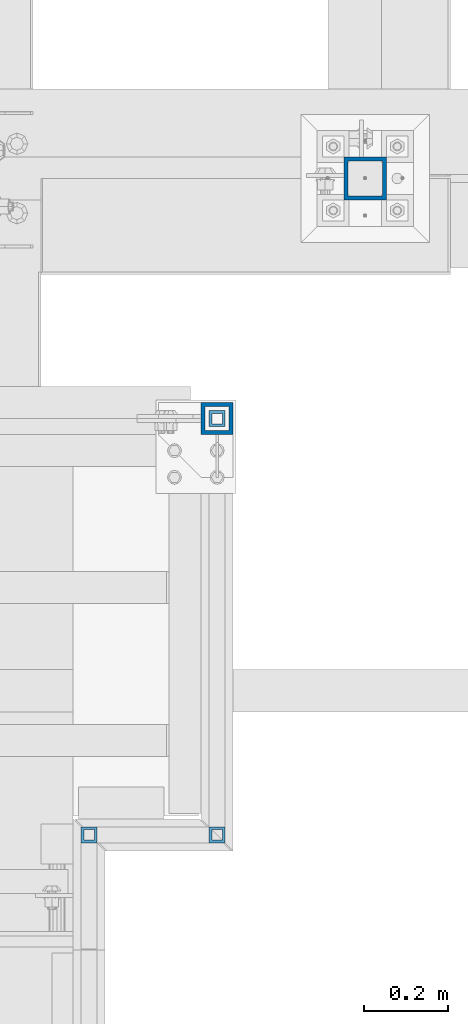
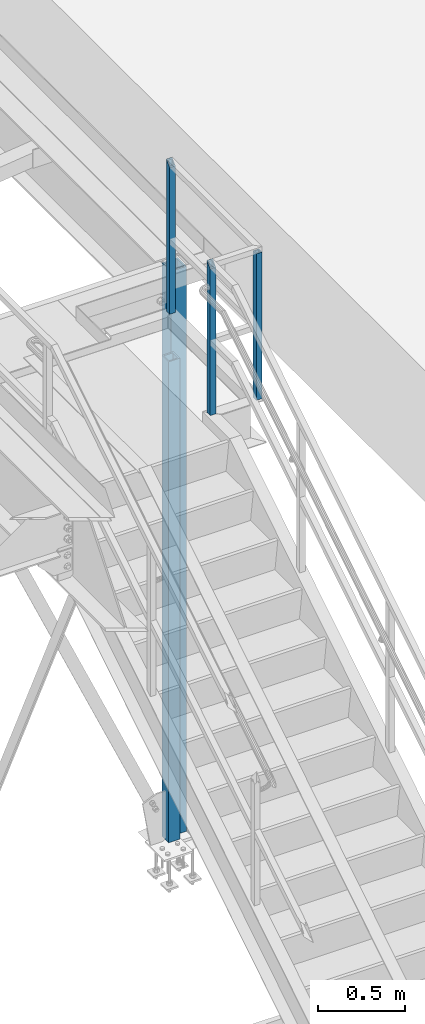
# One storey, part 1323 of 3843: 5 columns, 4 elements without a shape of their own.
"""IFC2X3 building model written with IfcOpenShell, lengths in millimetres."""

from ifc_helpers import new_model, si_unit, frame, origin_with_axes, place, context, subcontext, project, spatial, faceted_brep, material, type_object, element, aggregate, save


model = new_model("IFC2X3")

# Units and contexts
model_context = context("Model", 3, precision=1e-05, world=origin_with_axes())
body_context = subcontext(model_context, "Body", "Model", "MODEL_VIEW")
ifc_project = project(units=[si_unit("LENGTHUNIT", "METRE", prefix="MILLI"), si_unit("AREAUNIT", "SQUARE_METRE"), si_unit("VOLUMEUNIT", "CUBIC_METRE"), si_unit("MASSUNIT", "GRAM", prefix="KILO"), si_unit("TIMEUNIT", "SECOND"), si_unit("PLANEANGLEUNIT", "RADIAN"), si_unit("SOLIDANGLEUNIT", "STERADIAN"), si_unit("THERMODYNAMICTEMPERATUREUNIT", "DEGREE_CELSIUS"), si_unit("LUMINOUSINTENSITYUNIT", "LUMEN")], contexts=[model_context])

# Site, building, storey
site_placement = place(None, origin_with_axes())
site = spatial("IfcSite", under=ifc_project, at=site_placement, CompositionType="ELEMENT")
building_placement = place(site_placement, origin_with_axes())
building = spatial("IfcBuilding", under=site, at=building_placement, Name="Undefined", CompositionType="ELEMENT")
storey_placement = place(building_placement, origin_with_axes())
storey = spatial("IfcBuildingStorey", under=building, at=storey_placement, Name="Undefined", CompositionType="ELEMENT", Elevation=0.0)

# Assembly, columns
assembly_1_placement = place(storey_placement, origin_with_axes())
assembly_1 = element("IfcElementAssembly", 1, at=assembly_1_placement, inside=storey, Name="RAIL", AssemblyPlace="NOTDEFINED", PredefinedType="RIGID_FRAME")
ifc_material_1 = material()
column_type_1 = type_object("IfcColumnType", Name="HSS1-1/2X1-1/2X1/4", PredefinedType="NOTDEFINED")
column_1_placement = place(assembly_1_placement, frame((38468.2999999524, 33274.0, 34163.0), z_axis=(0.0, -1.0, 0.0), x_axis=(0.0, 0.0, 1.0)))
column_1 = element("IfcColumn", 2, at=column_1_placement, type_object=column_type_1, material=ifc_material_1, Name="POST", ObjectType="HSS1-1/2X1-1/2X1/4", context=body_context, shape_type="Brep", body=[
    faceted_brep([(0.0, 12.6999993299978, -12.6999993300014), (0.0, -12.6999993299978, -12.6999993300014), (1054.10000067001, -12.6999993300014, -12.6999993299978), (1054.10000067001, 12.6999993300014, -12.6999993299978), (0.0, -12.6999993299978, 12.6999993300014), (1028.70000067002, -12.6999993299978, 12.6999993299978), (0.0, 12.6999993299978, 12.6999993300014), (1028.70000067002, 12.6999993299978, 12.6999993299978), (0.0, 19.0500000000029, -19.0499999999993), (0.0, 19.0499992350015, 19.0499992350015), (1022.35000076501, 19.0499992350015, 19.0499992350015), (1060.44999923502, 19.0499992350015, -19.0499992350015), (0.0, -19.0499992350015, 19.0499992350015), (1022.35000076501, -19.0499992350015, 19.0499992350015), (0.0, -19.0499992350015, -19.0499992350015), (1060.44999923502, -19.0499992350015, -19.0499992350015)], [[[0, 1, 2, 3]], [[1, 4, 5, 2]], [[4, 6, 7, 5]], [[6, 0, 3, 7]], [[8, 9, 10, 11]], [[9, 12, 13, 10]], [[12, 14, 15, 13]], [[14, 8, 11, 15]], [[13, 15, 11, 10], [5, 7, 3, 2]], [[14, 12, 9, 8], [6, 4, 1, 0]]]),
])
column_2_placement = place(assembly_1_placement, frame((38468.2999999524, 32283.4, 34163.0), z_axis=(0.0, -1.0, 0.0), x_axis=(0.0, 0.0, 1.0)))
column_2 = element("IfcColumn", 3, at=column_2_placement, type_object=column_type_1, material=ifc_material_1, Name="POST", ObjectType="HSS1-1/2X1-1/2X1/4", context=body_context, shape_type="Brep", body=[
    faceted_brep([(0.0, 12.6999993299978, -12.6999993300014), (0.0, -12.6999993299978, -12.6999993300014), (1022.35000076501, -12.6999993299978, -12.6999993300014), (1022.35000076501, 12.6999993299978, -12.6999993300014), (0.0, -12.6999993299978, 12.6999993300014), (1022.35000076501, -12.6999993299978, 12.6999993300014), (0.0, 12.6999993299978, 12.6999993300014), (1022.35000076501, 12.6999993299978, 12.6999993300014), (0.0, 19.0500000000029, -19.0499999999993), (0.0, 19.0499992350015, 19.0499992350015), (1022.35000076501, 19.0499992350015, 19.0499992350015), (1022.35000076501, 19.0499992350015, -19.0499992350015), (0.0, -19.0499992350015, 19.0499992350015), (1022.35000076501, -19.0499992350015, 19.0499992350015), (0.0, -19.0499992350015, -19.0499992350015), (1022.35000076501, -19.0499992350015, -19.0499992350015)], [[[0, 1, 2, 3]], [[1, 4, 5, 2]], [[4, 6, 7, 5]], [[6, 0, 3, 7]], [[8, 9, 10, 11]], [[9, 12, 13, 10]], [[12, 14, 15, 13]], [[14, 8, 11, 15]], [[13, 15, 11, 10], [5, 7, 3, 2]], [[14, 12, 9, 8], [6, 4, 1, 0]]]),
])
aggregate(assembly_1, [column_1, column_2])

# Assembly, column
assembly_2_placement = place(storey_placement, origin_with_axes())
assembly_2 = element("IfcElementAssembly", 4, at=assembly_2_placement, inside=storey, Name="RAIL", AssemblyPlace="NOTDEFINED", PredefinedType="RIGID_FRAME")
column_3_placement = place(assembly_2_placement, frame((38163.4999999524, 32283.4, 34137.6), z_axis=(0.0, -1.0, 0.0), x_axis=(0.0, 0.0, 1.0)))
column_3 = element("IfcColumn", 5, at=column_3_placement, type_object=column_type_1, material=ifc_material_1, Name="POST", ObjectType="HSS1-1/2X1-1/2X1/4", context=body_context, shape_type="Brep", body=[
    faceted_brep([(1047.75000076629, -19.0499992350015, 19.0499992349942), (1047.75000076629, 19.0499992350015, 19.0499992349942), (25.4000000135893, 19.0499992350015, 19.0499992349942), (25.4000000135893, -19.0499992350015, 19.0499992349942), (1085.84999923629, -19.0499992350015, -19.0499992349942), (25.4000000135893, -19.0499992350015, -19.0499992349942), (1085.84999923629, 19.0499992350015, -19.0499992349942), (25.4000000135893, 19.0499992350015, -19.0499992349942), (1054.10000067129, -12.6999993300014, 12.6999993299978), (1054.10000067129, 12.6999993300014, 12.6999993299978), (1079.49999933128, 12.6999993300014, -12.6999993299978), (1079.49999933128, -12.6999993300014, -12.6999993299978), (25.4000000135893, -12.6999993300014, 12.6999993299978), (25.4000000135893, 12.6999993300014, 12.6999993299978), (25.4000000135893, 12.6999993300014, -12.6999993299978), (25.4000000135893, -12.6999993300014, -12.6999993299978)], [[[0, 1, 2, 3]], [[4, 0, 3, 5]], [[6, 4, 5, 7]], [[1, 6, 7, 2]], [[0, 4, 6, 1], [8, 9, 10, 11]], [[9, 8, 12, 13]], [[10, 9, 13, 14]], [[11, 10, 14, 15]], [[8, 11, 15, 12]], [[7, 5, 3, 2], [14, 13, 12, 15]]]),
])
aggregate(assembly_2, [column_3])

assembly_3_placement = place(storey_placement, origin_with_axes())
assembly_3 = element("IfcElementAssembly", 6, at=assembly_3_placement, inside=storey, Name="COLUMN", AssemblyPlace="NOTDEFINED", PredefinedType="RIGID_FRAME")
ifc_material_2 = material()
column_type_2 = type_object("IfcColumnType", Name="HSS4X4X3/8", PredefinedType="NOTDEFINED")
column_4_placement = place(assembly_3_placement, frame((38820.725, 33845.5, 30022.8), z_axis=(-1.0, 0.0, 0.0), x_axis=(0.0, 0.0, 1.0)))
column_4 = element("IfcColumn", 7, at=column_4_placement, type_object=column_type_2, material=ifc_material_2, Name="COLUMN", ObjectType="HSS4X4X3/8", context=body_context, shape_type="Brep", body=[
    faceted_brep([(57.1500000000015, 41.2749999999942, -41.2750000000015), (57.1500000000015, -41.2749999999942, -41.2750000000015), (4000.5, -41.2749999999942, -41.2750000000015), (4000.5, 41.2749999999942, -41.2750000000015), (57.1500000000015, -41.2749999999942, 41.2750000000015), (4000.5, -41.2749999999942, 41.2750000000015), (57.1500000000015, 41.2749999999942, 41.2750000000015), (4000.5, 41.2749999999942, 41.2750000000015), (57.1500000000015, 50.8000000000029, -50.8000000000029), (57.1500000000015, 50.8000000000029, 50.8000000000029), (4000.5, 50.8000000000029, 50.8000000000029), (4000.5, 50.8000000000029, -50.8000000000029), (57.1500000000015, -50.8000000000029, 50.8000000000029), (4000.5, -50.8000000000029, 50.8000000000029), (57.1500000000015, -50.8000000000029, -50.8000000000029), (4000.5, -50.8000000000029, -50.8000000000029)], [[[0, 1, 2, 3]], [[1, 4, 5, 2]], [[4, 6, 7, 5]], [[6, 0, 3, 7]], [[8, 9, 10, 11]], [[9, 12, 13, 10]], [[12, 14, 15, 13]], [[14, 8, 11, 15]], [[13, 15, 11, 10], [5, 7, 3, 2]], [[14, 12, 9, 8], [6, 4, 1, 0]]]),
])
aggregate(assembly_3, [column_4])

assembly_4_placement = place(storey_placement, origin_with_axes())
assembly_4 = element("IfcElementAssembly", 8, at=assembly_4_placement, inside=storey, Name="POST", AssemblyPlace="NOTDEFINED", PredefinedType="RIGID_FRAME")
column_type_3 = type_object("IfcColumnType", Name="HSS3X3X3/8", PredefinedType="NOTDEFINED")
column_5_placement = place(assembly_4_placement, frame((38468.3, 33274.0000000016, 30480.0), z_axis=(-1.0, 0.0, 0.0), x_axis=(0.0, 0.0, 1.0)))
column_5 = element("IfcColumn", 9, at=column_5_placement, type_object=column_type_3, material=ifc_material_2, Name="POST", ObjectType="HSS3X3X3/8", context=body_context, shape_type="Brep", body=[
    faceted_brep([(12.7000000000007, 28.5749999999971, -28.5749999999971), (12.7000000000007, -28.5749999999971, -28.5749999999971), (3368.67499999999, -28.5749999999971, -28.5749999999971), (3368.67499999999, 28.5749999999971, -28.5749999999971), (12.7000000000007, -28.5749999999971, 28.5749999999971), (3368.67499999999, -28.5749999999971, 28.5749999999971), (12.7000000000007, 28.5749999999971, 28.5749999999971), (3368.67499999999, 28.5749999999971, 28.5749999999971), (12.7000000000007, 38.1000000000058, -38.0999999999985), (12.7000000000007, 38.1000000000058, 38.0999999999985), (3368.67499999999, 38.1000000000058, 38.0999999999985), (3368.67499999999, 38.1000000000058, -38.0999999999985), (12.7000000000007, -38.1000000000058, 38.0999999999985), (3368.67499999999, -38.1000000000058, 38.0999999999985), (12.7000000000007, -38.1000000000058, -38.0999999999985), (3368.67499999999, -38.1000000000058, -38.0999999999985)], [[[0, 1, 2, 3]], [[1, 4, 5, 2]], [[4, 6, 7, 5]], [[6, 0, 3, 7]], [[8, 9, 10, 11]], [[9, 12, 13, 10]], [[12, 14, 15, 13]], [[14, 8, 11, 15]], [[13, 15, 11, 10], [5, 7, 3, 2]], [[14, 12, 9, 8], [6, 4, 1, 0]]]),
])
aggregate(assembly_4, [column_5])

save(model, "model.ifc")
